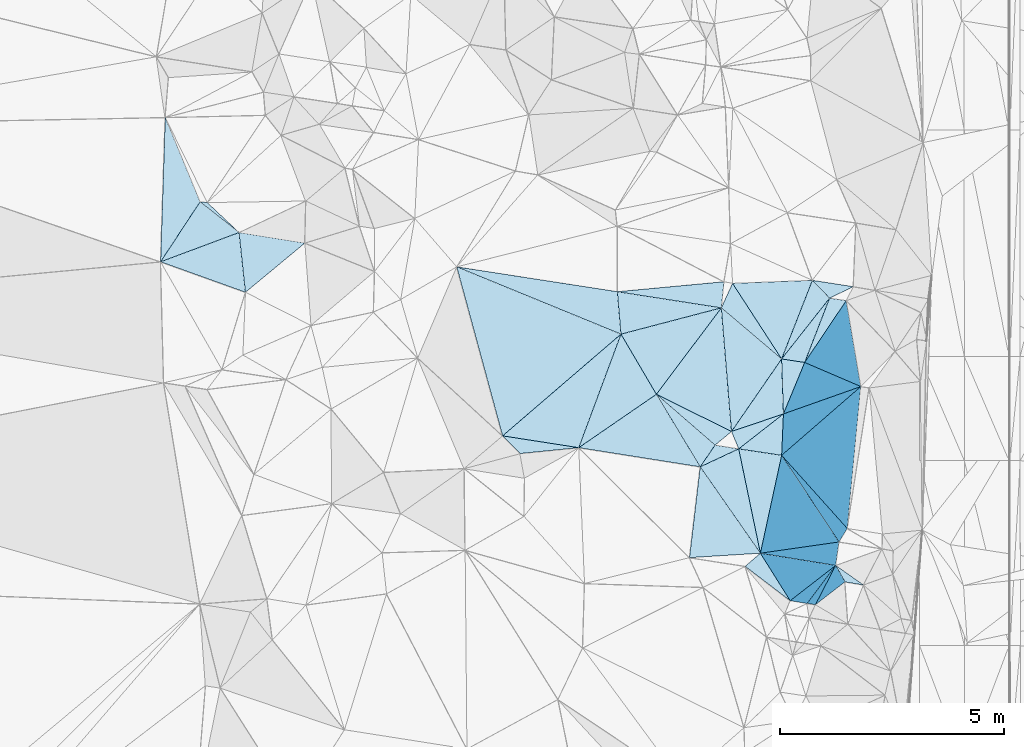
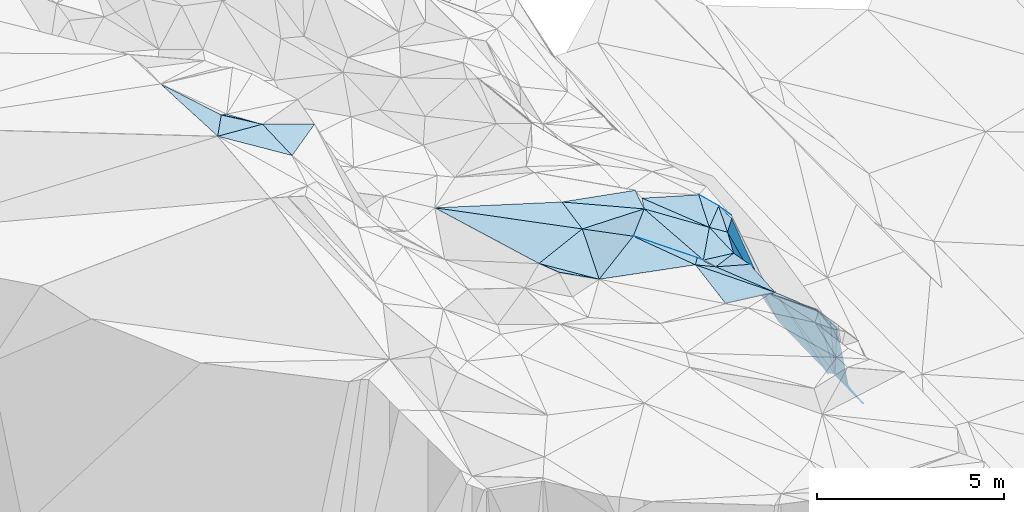
# One storey, part 133 of 275: 45 plates.
"""IFC2X3 building model written with IfcOpenShell, lengths in millimetres."""

from ifc_helpers import new_model, si_unit, frame, origin_with_axes, place, context, subcontext, project, spatial, polyline, outline, extrude, material, type_object, element, save


model = new_model("IFC2X3")

# Units and contexts
model_context = context("Model", 3, precision=1e-05, world=origin_with_axes())
body_context = subcontext(model_context, "Body", "Model", "MODEL_VIEW")
ifc_project = project(units=[si_unit("LENGTHUNIT", "METRE", prefix="MILLI"), si_unit("AREAUNIT", "SQUARE_METRE"), si_unit("VOLUMEUNIT", "CUBIC_METRE"), si_unit("MASSUNIT", "GRAM", prefix="KILO"), si_unit("TIMEUNIT", "SECOND"), si_unit("PLANEANGLEUNIT", "RADIAN"), si_unit("SOLIDANGLEUNIT", "STERADIAN"), si_unit("THERMODYNAMICTEMPERATUREUNIT", "DEGREE_CELSIUS"), si_unit("LUMINOUSINTENSITYUNIT", "LUMEN")], contexts=[model_context])

# Site, building, storey
site_placement = place(None, origin_with_axes())
site = spatial("IfcSite", under=ifc_project, at=site_placement, CompositionType="ELEMENT")
building_placement = place(site_placement, origin_with_axes())
building = spatial("IfcBuilding", under=site, at=building_placement, Name="Undefined", CompositionType="ELEMENT")
storey_placement = place(building_placement, origin_with_axes())
storey = spatial("IfcBuildingStorey", under=building, at=storey_placement, Name="Undefined", CompositionType="ELEMENT", Elevation=0.0)

# Plates
ifc_material = material()
plate_type_1 = type_object("IfcPlateType", PredefinedType="NOTDEFINED")
plate_1_placement = place(storey_placement, frame((-103541.846860155, 120689.424608109, 51749.5258270343), z_axis=(-0.131431408662991, -0.288877952959774, -0.94830127760677), x_axis=(-0.498027157228979, 0.846359246824753, -0.188798771120629)))
element("IfcPlate", 1, at=plate_1_placement, inside=storey, type_object=plate_type_1, material=ifc_material, Name="00", context=body_context, shape_type="SweptSolid", body=[
    extrude(outline(polyline([(0.0, 0.0), (1588.99340820313, -1.13286660052836e-08), (1061.17492675781, 2311.38647460938), (0.0, 0.0)])), frame((-8.85201319254618e-08, 2.18876761149539e-07, -0.5000001331573), z_axis=(0.0, 0.0, 1.0), x_axis=(1.0, 0.0, 0.0)), (0.0, 0.0, 1.0), 1.0),
])
plate_type_2 = type_object("IfcPlateType", PredefinedType="NOTDEFINED")
plate_2_placement = place(storey_placement, frame((-100226.529970155, 121400.937485137, 50289.5630769742), z_axis=(-0.483352519640006, 0.0532796834257402, -0.87380296239582), x_axis=(-0.86409887648363, 0.131009605801975, 0.485972854023082)))
element("IfcPlate", 2, at=plate_2_placement, inside=storey, type_object=plate_type_2, material=ifc_material, Name="00", context=body_context, shape_type="SweptSolid", body=[
    extrude(outline(polyline([(0.0, 0.0), (596.741149902344, 2.91038304567337e-11), (-399.168060302734, 1505.07971191406), (0.0, 0.0)])), frame((-8.85201319254618e-08, 2.18876761149539e-07, -0.5000001331573), z_axis=(0.0, 0.0, 1.0), x_axis=(1.0, 0.0, 0.0)), (0.0, 0.0, 1.0), 1.0),
])
plate_type_3 = type_object("IfcPlateType", PredefinedType="NOTDEFINED")
plate_3_placement = place(storey_placement, frame((-99670.4874775503, 122838.670815847, 50069.7001514242), z_axis=(-0.77295251631372, 0.207269783527302, -0.599652936589853), x_axis=(0.59631552323439, -0.0854564328444867, -0.798188570975049)))
element("IfcPlate", 3, at=plate_3_placement, inside=storey, type_object=plate_type_3, material=ifc_material, Name="00", context=body_context, shape_type="SweptSolid", body=[
    extrude(outline(polyline([(0.0, 0.0), (626.418395996094, -1.62981450557709e-09), (-384.407623291016, 1508.91711425781), (0.0, 0.0)])), frame((-8.85201319254618e-08, 2.18876761149539e-07, -0.5000001331573), z_axis=(0.0, 0.0, 1.0), x_axis=(1.0, 0.0, 0.0)), (0.0, 0.0, 1.0), 1.0),
])
plate_type_4 = type_object("IfcPlateType", PredefinedType="NOTDEFINED")
plate_4_placement = place(storey_placement, frame((-113742.713337974, 124992.402034436, 56659.5075099544), z_axis=(-0.108946506484557, 0.134320696726159, -0.984930763635602), x_axis=(0.987147536895486, -0.101922643665445, -0.123091490808351)))
element("IfcPlate", 4, at=plate_4_placement, inside=storey, type_object=plate_type_4, material=ifc_material, Name="00", context=body_context, shape_type="SweptSolid", body=[
    extrude(outline(polyline([(0.0, 0.0), (162.480773925781, -1.12049747258425e-09), (953.959045410156, 597.37939453125), (0.0, 0.0)])), frame((-8.85201319254618e-08, 2.18876761149539e-07, -0.5000001331573), z_axis=(0.0, 0.0, 1.0), x_axis=(1.0, 0.0, 0.0)), (0.0, 0.0, 1.0), 1.0),
])
plate_type_5 = type_object("IfcPlateType", PredefinedType="NOTDEFINED")
plate_5_placement = place(storey_placement, frame((-114521.961867729, 126878.314157628, 56799.5320666734), z_axis=(-0.34484448311101, -0.072992193626114, -0.935817515404338), x_axis=(0.380916672105907, -0.922072470354693, -0.0684459518580531)))
element("IfcPlate", 5, at=plate_5_placement, inside=storey, type_object=plate_type_5, material=ifc_material, Name="00", context=body_context, shape_type="SweptSolid", body=[
    extrude(outline(polyline([(0.0, 0.0), (2045.40954589844, 7.27595761418343e-09), (2916.67749023438, 1416.04797363281), (0.0, 0.0)])), frame((-8.85201319254618e-08, 2.18876761149539e-07, -0.5000001331573), z_axis=(0.0, 0.0, 1.0), x_axis=(1.0, 0.0, 0.0)), (0.0, 0.0, 1.0), 1.0),
])
plate_type_6 = type_object("IfcPlateType", PredefinedType="NOTDEFINED")
plate_6_placement = place(storey_placement, frame((-106979.791347258, 119760.129287109, 52629.5671899725), z_axis=(-0.494926142917459, -0.0763462852968208, -0.865574582446956), x_axis=(0.865298196313905, -0.13434608578949, -0.482918378909879)))
element("IfcPlate", 6, at=plate_6_placement, inside=storey, type_object=plate_type_6, material=ifc_material, Name="00", context=body_context, shape_type="SweptSolid", body=[
    extrude(outline(polyline([(0.0, 0.0), (1967.20617675781, 1.2732925824821e-08), (485.002563476563, 333.575378417969), (0.0, 0.0)])), frame((-8.85201319254618e-08, 2.18876761149539e-07, -0.5000001331573), z_axis=(0.0, 0.0, 1.0), x_axis=(1.0, 0.0, 0.0)), (0.0, 0.0, 1.0), 1.0),
])
plate_type_7 = type_object("IfcPlateType", PredefinedType="NOTDEFINED")
plate_7_placement = place(storey_placement, frame((-100550.887940375, 116074.807698265, 51109.8012730318), z_axis=(-0.801516270821083, -0.446807466458968, -0.397410059668328), x_axis=(-0.527769777279548, 0.841029329900626, 0.118864327858281)))
element("IfcPlate", 7, at=plate_7_placement, inside=storey, type_object=plate_type_7, material=ifc_material, Name="00", context=body_context, shape_type="SweptSolid", body=[
    extrude(outline(polyline([(0.0, 0.0), (1261.94299316406, 1.00990291684866e-08), (-223.147964477539, 3201.93774414063), (0.0, 0.0)])), frame((-8.85201319254618e-08, 2.18876761149539e-07, -0.5000001331573), z_axis=(0.0, 0.0, 1.0), x_axis=(1.0, 0.0, 0.0)), (0.0, 0.0, 1.0), 1.0),
])
plate_type_8 = type_object("IfcPlateType", PredefinedType="NOTDEFINED")
plate_8_placement = place(storey_placement, frame((-102089.213282242, 122622.15882844, 50959.5547884261), z_axis=(-0.255608616383563, 0.376682940142847, -0.890378682267169), x_axis=(-0.933088162262274, 0.144894729744456, 0.329168647866552)))
element("IfcPlate", 8, at=plate_8_placement, inside=storey, type_object=plate_type_8, material=ifc_material, Name="00", context=body_context, shape_type="SweptSolid", body=[
    extrude(outline(polyline([(0.0, 0.0), (2491.12426757813, -9.89530235528946e-10), (105.213539123535, 621.313232421875), (0.0, 0.0)])), frame((-8.85201319254618e-08, 2.18876761149539e-07, -0.5000001331573), z_axis=(0.0, 0.0, 1.0), x_axis=(1.0, 0.0, 0.0)), (0.0, 0.0, 1.0), 1.0),
])
plate_type_9 = type_object("IfcPlateType", PredefinedType="NOTDEFINED")
plate_9_placement = place(storey_placement, frame((-100741.518688429, 119325.498111295, 50679.7574045136), z_axis=(-0.871375474883177, -0.0730486686952182, -0.485148094682411), x_axis=(0.0414887717409885, 0.97434003179237, -0.221224284983065)))
element("IfcPlate", 9, at=plate_9_placement, inside=storey, type_object=plate_type_9, material=ifc_material, Name="00", context=body_context, shape_type="SweptSolid", body=[
    extrude(outline(polyline([(0.0, 0.0), (949.262878417969, 8.00355337560177e-10), (2325.17260742188, 3422.77270507813), (0.0, 0.0)])), frame((-8.85201319254618e-08, 2.18876761149539e-07, -0.5000001331573), z_axis=(0.0, 0.0, 1.0), x_axis=(1.0, 0.0, 0.0)), (0.0, 0.0, 1.0), 1.0),
])
plate_type_10 = type_object("IfcPlateType", PredefinedType="NOTDEFINED")
plate_10_placement = place(storey_placement, frame((-112728.423283851, 122969.869598107, 56209.5417378106), z_axis=(-0.375448268043942, 0.138240768234035, -0.916475906950569), x_axis=(-0.862607535053377, 0.309589091692787, 0.400078535757634)))
element("IfcPlate", 10, at=plate_10_placement, inside=storey, type_object=plate_type_10, material=ifc_material, Name="00", context=body_context, shape_type="SweptSolid", body=[
    extrude(outline(polyline([(0.0, 0.0), (2199.56811523438, 2.35741026699543e-09), (640.762145996094, 1209.76196289063), (0.0, 0.0)])), frame((-8.85201319254618e-08, 2.18876761149539e-07, -0.5000001331573), z_axis=(0.0, 0.0, 1.0), x_axis=(1.0, 0.0, 0.0)), (0.0, 0.0, 1.0), 1.0),
])
plate_type_11 = type_object("IfcPlateType", PredefinedType="NOTDEFINED")
plate_11_placement = place(storey_placement, frame((-113742.80589089, 124992.279483565, 56659.5252998992), z_axis=(-0.29404704903762, -0.110761845372307, -0.949351434697388), x_axis=(0.774589887403005, -0.609520922904891, -0.168803882876462)))
element("IfcPlate", 11, at=plate_11_placement, inside=storey, type_object=plate_type_11, material=ifc_material, Name="00", context=body_context, shape_type="SweptSolid", body=[
    extrude(outline(polyline([(0.0, 0.0), (1125.56652832031, 1.1423253454268e-09), (61.2136192321777, 1661.4912109375), (0.0, 0.0)])), frame((-8.85201319254618e-08, 2.18876761149539e-07, -0.5000001331573), z_axis=(0.0, 0.0, 1.0), x_axis=(1.0, 0.0, 0.0)), (0.0, 0.0, 1.0), 1.0),
])
plate_type_12 = type_object("IfcPlateType", PredefinedType="NOTDEFINED")
plate_12_placement = place(storey_placement, frame((-101862.228640944, 119857.739316437, 50889.5565335684), z_axis=(-0.46172321911077, -0.0154724940966156, -0.886889097272268), x_axis=(-0.814508038136902, 0.403341117743197, 0.417004314783484)))
element("IfcPlate", 12, at=plate_12_placement, inside=storey, type_object=plate_type_12, material=ifc_material, Name="00", context=body_context, shape_type="SweptSolid", body=[
    extrude(outline(polyline([(0.0, 0.0), (2062.32885742188, -8.46921466290951e-09), (1329.080078125, 2435.353515625), (0.0, 0.0)])), frame((-8.85201319254618e-08, 2.18876761149539e-07, -0.5000001331573), z_axis=(0.0, 0.0, 1.0), x_axis=(1.0, 0.0, 0.0)), (0.0, 0.0, 1.0), 1.0),
])
plate_type_13 = type_object("IfcPlateType", PredefinedType="NOTDEFINED")
plate_13_placement = place(storey_placement, frame((-99986.4311561274, 115985.240943907, 50419.8036994692), z_axis=(-0.603850024931311, -0.693731928358291, -0.392557204706197), x_axis=(-0.611790406562096, 0.0876740989038801, 0.786146138335601)))
element("IfcPlate", 13, at=plate_13_placement, inside=storey, type_object=plate_type_13, material=ifc_material, Name="00", context=body_context, shape_type="SweptSolid", body=[
    extrude(outline(polyline([(0.0, 0.0), (305.286743164063, -2.7648638933897e-10), (-1969.29602050781, 1470.26293945313), (0.0, 0.0)])), frame((-8.85201319254618e-08, 2.18876761149539e-07, -0.5000001331573), z_axis=(0.0, 0.0, 1.0), x_axis=(1.0, 0.0, 0.0)), (0.0, 0.0, 1.0), 1.0),
])
plate_type_14 = type_object("IfcPlateType", PredefinedType="NOTDEFINED")
plate_14_placement = place(storey_placement, frame((-102230.427140432, 119552.697233883, 51269.6111809844), z_axis=(-0.549469294641196, -0.305664369536935, -0.77759423058694), x_axis=(-0.728356746078006, 0.631228113644776, 0.2665474047653)))
element("IfcPlate", 14, at=plate_14_placement, inside=storey, type_object=plate_type_14, material=ifc_material, Name="00", context=body_context, shape_type="SweptSolid", body=[
    extrude(outline(polyline([(0.0, 0.0), (1800.80541992188, 1.5788828022778e-09), (-176.976364135742, 584.447937011719), (0.0, 0.0)])), frame((-8.85201319254618e-08, 2.18876761149539e-07, -0.5000001331573), z_axis=(0.0, 0.0, 1.0), x_axis=(1.0, 0.0, 0.0)), (0.0, 0.0, 1.0), 1.0),
])
plate_type_15 = type_object("IfcPlateType", PredefinedType="NOTDEFINED")
plate_15_placement = place(storey_placement, frame((-101701.48378919, 119469.549244421, 50849.5281222413), z_axis=(-0.328493757168184, -0.0387278729901455, -0.943711822197428), x_axis=(-0.380737016365414, 0.919812811058864, 0.0947824719088557)))
element("IfcPlate", 15, at=plate_15_placement, inside=storey, type_object=plate_type_15, material=ifc_material, Name="00", context=body_context, shape_type="SweptSolid", body=[
    extrude(outline(polyline([(0.0, 0.0), (422.018951416016, 8.14907252788544e-10), (301.645202636719, 1289.34484863281), (0.0, 0.0)])), frame((-8.85201319254618e-08, 2.18876761149539e-07, -0.5000001331573), z_axis=(0.0, 0.0, 1.0), x_axis=(1.0, 0.0, 0.0)), (0.0, 0.0, 1.0), 1.0),
])
plate_type_16 = type_object("IfcPlateType", PredefinedType="NOTDEFINED")
plate_16_placement = place(storey_placement, frame((-100742.067157443, 121479.089966986, 50579.5186901572), z_axis=(-0.271011619986809, 0.000598922214104097, -0.962575889540304), x_axis=(-0.745502314234174, 0.632459540765163, 0.210288441828388)))
element("IfcPlate", 16, at=plate_16_placement, inside=storey, type_object=plate_type_16, material=ifc_material, Name="00", context=body_context, shape_type="SweptSolid", body=[
    extrude(outline(polyline([(0.0, 0.0), (1807.04174804688, 8.87666828930378e-09), (1952.52819824219, 588.416259765625), (0.0, 0.0)])), frame((-8.85201319254618e-08, 2.18876761149539e-07, -0.5000001331573), z_axis=(0.0, 0.0, 1.0), x_axis=(1.0, 0.0, 0.0)), (0.0, 0.0, 1.0), 1.0),
])
plate_type_17 = type_object("IfcPlateType", PredefinedType="NOTDEFINED")
plate_17_placement = place(storey_placement, frame((-103541.982905747, 120689.528675815, 51749.5442755358), z_axis=(-0.40351258670929, -0.0807452370194401, -0.911404300552643), x_axis=(0.728356746074451, -0.631228113648151, -0.266547404767021)))
element("IfcPlate", 17, at=plate_17_placement, inside=storey, type_object=plate_type_17, material=ifc_material, Name="00", context=body_context, shape_type="SweptSolid", body=[
    extrude(outline(polyline([(0.0, 0.0), (1800.80541992188, 1.5788828022778e-09), (1814.96569824219, 618.061096191406), (0.0, 0.0)])), frame((-8.85201319254618e-08, 2.18876761149539e-07, -0.5000001331573), z_axis=(0.0, 0.0, 1.0), x_axis=(1.0, 0.0, 0.0)), (0.0, 0.0, 1.0), 1.0),
])
plate_type_18 = type_object("IfcPlateType", PredefinedType="NOTDEFINED")
plate_18_placement = place(storey_placement, frame((-102089.220352531, 122621.971593678, 50959.5185117012), z_axis=(-0.269732162540713, 0.00222573903659112, -0.962932815193693), x_axis=(0.745502314238582, -0.632459540761654, -0.210288441823312)))
element("IfcPlate", 18, at=plate_18_placement, inside=storey, type_object=plate_type_18, material=ifc_material, Name="00", context=body_context, shape_type="SweptSolid", body=[
    extrude(outline(polyline([(0.0, 0.0), (1807.04174804688, 8.87666828930378e-09), (1932.27404785156, 1990.90856933594), (0.0, 0.0)])), frame((-8.85201319254618e-08, 2.18876761149539e-07, -0.5000001331573), z_axis=(0.0, 0.0, 1.0), x_axis=(1.0, 0.0, 0.0)), (0.0, 0.0, 1.0), 1.0),
])
plate_type_19 = type_object("IfcPlateType", PredefinedType="NOTDEFINED")
plate_19_placement = place(storey_placement, frame((-99532.995236247, 116863.941100128, 48169.7336891766), z_axis=(-0.840983119391418, -0.0954332160620175, -0.53257853333639), x_axis=(0.526493796418976, -0.371211237004124, -0.764857176114732)))
element("IfcPlate", 19, at=plate_19_placement, inside=storey, type_object=plate_type_19, material=ifc_material, Name="00", context=body_context, shape_type="SweptSolid", body=[
    extrude(outline(polyline([(0.0, 0.0), (1176.69030761719, 1.57160684466362e-09), (444.127075195313, 219.888946533203), (0.0, 0.0)])), frame((-8.85201319254618e-08, 2.18876761149539e-07, -0.5000001331573), z_axis=(0.0, 0.0, 1.0), x_axis=(1.0, 0.0, 0.0)), (0.0, 0.0, 1.0), 1.0),
])
plate_type_20 = type_object("IfcPlateType", PredefinedType="NOTDEFINED")
plate_20_placement = place(storey_placement, frame((-100742.112039479, 121479.125392568, 50579.5350233442), z_axis=(-0.360783035322879, 0.0714400955290196, -0.929909626885331), x_axis=(0.0325974243393763, -0.995486879358179, -0.0891250859867933)))
element("IfcPlate", 20, at=plate_20_placement, inside=storey, type_object=plate_type_20, material=ifc_material, Name="00", context=body_context, shape_type="SweptSolid", body=[
    extrude(outline(polyline([(0.0, 0.0), (1234.22045898438, -5.58793544769287e-09), (1549.88525390625, 1255.88842773438), (0.0, 0.0)])), frame((-8.85201319254618e-08, 2.18876761149539e-07, -0.5000001331573), z_axis=(0.0, 0.0, 1.0), x_axis=(1.0, 0.0, 0.0)), (0.0, 0.0, 1.0), 1.0),
])
plate_type_21 = type_object("IfcPlateType", PredefinedType="NOTDEFINED")
plate_21_placement = place(storey_placement, frame((-101216.742749656, 117136.238297007, 51259.5793100965), z_axis=(-0.480428425201294, -0.247671150915636, -0.841336751403818), x_axis=(-0.569712309594849, 0.817470260301661, 0.0846773748910366)))
element("IfcPlate", 21, at=plate_21_placement, inside=storey, type_object=plate_type_21, material=ifc_material, Name="00", context=body_context, shape_type="SweptSolid", body=[
    extrude(outline(polyline([(0.0, 0.0), (2361.90600585938, 8.70204530656338e-09), (2148.8154296875, 1108.86987304688), (0.0, 0.0)])), frame((-8.85201319254618e-08, 2.18876761149539e-07, -0.5000001331573), z_axis=(0.0, 0.0, 1.0), x_axis=(1.0, 0.0, 0.0)), (0.0, 0.0, 1.0), 1.0),
])
plate_type_22 = type_object("IfcPlateType", PredefinedType="NOTDEFINED")
plate_22_placement = place(storey_placement, frame((-100701.799625486, 120250.33507261, 50469.5214105285), z_axis=(-0.200766038471775, -0.208769099764669, -0.957135549846415), x_axis=(-0.0414887717289393, -0.974340031793671, 0.221224284979592)))
element("IfcPlate", 22, at=plate_22_placement, inside=storey, type_object=plate_type_22, material=ifc_material, Name="00", context=body_context, shape_type="SweptSolid", body=[
    extrude(outline(polyline([(0.0, 0.0), (949.262878417969, 8.00355337560177e-10), (886.371948242188, 983.740173339844), (0.0, 0.0)])), frame((-8.85201319254618e-08, 2.18876761149539e-07, -0.5000001331573), z_axis=(0.0, 0.0, 1.0), x_axis=(1.0, 0.0, 0.0)), (0.0, 0.0, 1.0), 1.0),
])
plate_type_23 = type_object("IfcPlateType", PredefinedType="NOTDEFINED")
plate_23_placement = place(storey_placement, frame((-104333.281442112, 122034.575677004, 51449.5426835672), z_axis=(-0.276873322370097, 0.29473957989941, -0.91458719835807), x_axis=(-0.0797848573698835, 0.941458303007926, 0.327552499962836)))
element("IfcPlate", 23, at=plate_23_placement, inside=storey, type_object=plate_type_23, material=ifc_material, Name="00", context=body_context, shape_type="SweptSolid", body=[
    extrude(outline(polyline([(0.0, 0.0), (1007.47210693359, -5.83531800657511e-09), (213.603927612305, 2361.244140625), (0.0, 0.0)])), frame((-8.85201319254618e-08, 2.18876761149539e-07, -0.5000001331573), z_axis=(0.0, 0.0, 1.0), x_axis=(1.0, 0.0, 0.0)), (0.0, 0.0, 1.0), 1.0),
])
plate_type_24 = type_object("IfcPlateType", PredefinedType="NOTDEFINED")
plate_24_placement = place(storey_placement, frame((-100550.726125121, 116074.941939383, 51109.569913489), z_axis=(-0.477889012652295, -0.178325172223778, -0.860129190608931), x_axis=(-0.757948783837935, 0.57863717151048, 0.301152228656781)))
element("IfcPlate", 24, at=plate_24_placement, inside=storey, type_object=plate_type_24, material=ifc_material, Name="00", context=body_context, shape_type="SweptSolid", body=[
    extrude(outline(polyline([(0.0, 0.0), (1328.23193359375, 5.56610757485032e-09), (1164.10388183594, 487.198120117188), (0.0, 0.0)])), frame((-8.85201319254618e-08, 2.18876761149539e-07, -0.5000001331573), z_axis=(0.0, 0.0, 1.0), x_axis=(1.0, 0.0, 0.0)), (0.0, 0.0, 1.0), 1.0),
])
plate_type_25 = type_object("IfcPlateType", PredefinedType="NOTDEFINED")
plate_25_placement = place(storey_placement, frame((-100741.517646329, 119325.593728318, 50679.7599971177), z_axis=(-0.869290872854774, 0.118190313701849, -0.479962944526392), x_axis=(0.389385195380708, -0.43439224899537, -0.8122084360748)))
element("IfcPlate", 25, at=plate_25_placement, inside=storey, type_object=plate_type_25, material=ifc_material, Name="00", context=body_context, shape_type="SweptSolid", body=[
    extrude(outline(polyline([(0.0, 0.0), (3767.505859375, 1.32713466882706e-08), (3614.93798828125, 410.393798828125), (0.0, 0.0)])), frame((-8.85201319254618e-08, 2.18876761149539e-07, -0.5000001331573), z_axis=(0.0, 0.0, 1.0), x_axis=(1.0, 0.0, 0.0)), (0.0, 0.0, 1.0), 1.0),
])
plate_type_26 = type_object("IfcPlateType", PredefinedType="NOTDEFINED")
plate_26_placement = place(storey_placement, frame((-100701.94026098, 120250.470679995, 50469.5630154226), z_axis=(-0.482030028689172, 0.0624576428661563, -0.873925680072121), x_axis=(-0.0325974243505657, 0.995486879357683, 0.0891250859882445)))
element("IfcPlate", 26, at=plate_26_placement, inside=storey, type_object=plate_type_26, material=ifc_material, Name="00", context=body_context, shape_type="SweptSolid", body=[
    extrude(outline(polyline([(0.0, 0.0), (1234.22045898438, -5.58793544769287e-09), (1113.73950195313, 584.452209472656), (0.0, 0.0)])), frame((-8.85201319254618e-08, 2.18876761149539e-07, -0.5000001331573), z_axis=(0.0, 0.0, 1.0), x_axis=(1.0, 0.0, 0.0)), (0.0, 0.0, 1.0), 1.0),
])
plate_type_27 = type_object("IfcPlateType", PredefinedType="NOTDEFINED")
plate_27_placement = place(storey_placement, frame((-104333.075349968, 122034.358695552, 51449.509489574), z_axis=(0.135310557615119, -0.139206381422751, -0.980975349521622), x_axis=(0.49802715722236, -0.846359246829393, 0.188798771117288)))
element("IfcPlate", 27, at=plate_27_placement, inside=storey, type_object=plate_type_27, material=ifc_material, Name="00", context=body_context, shape_type="SweptSolid", body=[
    extrude(outline(polyline([(0.0, 0.0), (1588.99340820313, -1.13286660052836e-08), (1721.71887207031, 2103.39819335938), (0.0, 0.0)])), frame((-8.85201319254618e-08, 2.18876761149539e-07, -0.5000001331573), z_axis=(0.0, 0.0, 1.0), x_axis=(1.0, 0.0, 0.0)), (0.0, 0.0, 1.0), 1.0),
])
plate_type_28 = type_object("IfcPlateType", PredefinedType="NOTDEFINED")
plate_28_placement = place(storey_placement, frame((-99533.0281184381, 116863.840097702, 48169.8505274639), z_axis=(-0.906746001628498, -0.29743820597445, -0.298901659676612), x_axis=(0.416498651386256, -0.742485403038423, -0.524637302970634)))
element("IfcPlate", 28, at=plate_28_placement, inside=storey, type_object=plate_type_28, material=ifc_material, Name="00", context=body_context, shape_type="SweptSolid", body=[
    extrude(outline(polyline([(0.0, 0.0), (495.580474853516, -2.11002770811319e-10), (-717.138854980469, 2350.640625), (0.0, 0.0)])), frame((-8.85201319254618e-08, 2.18876761149539e-07, -0.5000001331573), z_axis=(0.0, 0.0, 1.0), x_axis=(1.0, 0.0, 0.0)), (0.0, 0.0, 1.0), 1.0),
])
plate_type_29 = type_object("IfcPlateType", PredefinedType="NOTDEFINED")
plate_29_placement = place(storey_placement, frame((-99670.4508953865, 122838.45027632, 50069.6624709867), z_axis=(-0.699778923062208, -0.233806966262561, -0.675013897164343), x_axis=(-0.627878852442615, 0.651972237964554, 0.425088634967857)))
element("IfcPlate", 29, at=plate_29_placement, inside=storey, type_object=plate_type_29, material=ifc_material, Name="00", context=body_context, shape_type="SweptSolid", body=[
    extrude(outline(polyline([(0.0, 0.0), (611.637145996094, -7.34871719032526e-10), (-438.331787109375, 752.306640625), (0.0, 0.0)])), frame((-8.85201319254618e-08, 2.18876761149539e-07, -0.5000001331573), z_axis=(0.0, 0.0, 1.0), x_axis=(1.0, 0.0, 0.0)), (0.0, 0.0, 1.0), 1.0),
])
plate_type_30 = type_object("IfcPlateType", PredefinedType="NOTDEFINED")
plate_30_placement = place(storey_placement, frame((-102562.413391558, 119067.203897725, 51459.6066201978), z_axis=(-0.607851130657934, 0.107689277198541, -0.786714702121632), x_axis=(0.536953372818032, 0.785638536151862, -0.307332337921831)))
element("IfcPlate", 30, at=plate_30_placement, inside=storey, type_object=plate_type_30, material=ifc_material, Name="00", context=body_context, shape_type="SweptSolid", body=[
    extrude(outline(polyline([(0.0, 0.0), (618.223266601563, 3.49245965480804e-10), (965.832336425781, 584.951232910156), (0.0, 0.0)])), frame((-8.85201319254618e-08, 2.18876761149539e-07, -0.5000001331573), z_axis=(0.0, 0.0, 1.0), x_axis=(1.0, 0.0, 0.0)), (0.0, 0.0, 1.0), 1.0),
])
plate_type_31 = type_object("IfcPlateType", PredefinedType="NOTDEFINED")
plate_31_placement = place(storey_placement, frame((-108004.806452899, 123538.417136166, 52509.5306992463), z_axis=(-0.142150807506572, 0.314495687797678, -0.938555065130382), x_axis=(0.96889703997134, -0.149828539686607, -0.196951604792028)))
element("IfcPlate", 31, at=plate_31_placement, inside=storey, type_object=plate_type_31, material=ifc_material, Name="00", context=body_context, shape_type="SweptSolid", body=[
    extrude(outline(polyline([(0.0, 0.0), (3706.49438476563, 1.20489858090878e-08), (3991.48046875, 966.324401855469), (0.0, 0.0)])), frame((-8.85201319254618e-08, 2.18876761149539e-07, -0.5000001331573), z_axis=(0.0, 0.0, 1.0), x_axis=(1.0, 0.0, 0.0)), (0.0, 0.0, 1.0), 1.0),
])
plate_type_32 = type_object("IfcPlateType", PredefinedType="NOTDEFINED")
plate_32_placement = place(storey_placement, frame((-100173.193759468, 116011.999268678, 50659.8034526401), z_axis=(-0.586048174918545, -0.708560776686435, -0.393051093900219), x_axis=(-0.639151309523926, 0.106096074900835, 0.761727790240377)))
element("IfcPlate", 32, at=plate_32_placement, inside=storey, type_object=plate_type_32, material=ifc_material, Name="00", context=body_context, shape_type="SweptSolid", body=[
    extrude(outline(polyline([(0.0, 0.0), (590.76220703125, -1.60071067512035e-10), (-2215.6123046875, 1557.71069335938), (0.0, 0.0)])), frame((-8.85201319254618e-08, 2.18876761149539e-07, -0.5000001331573), z_axis=(0.0, 0.0, 1.0), x_axis=(1.0, 0.0, 0.0)), (0.0, 0.0, 1.0), 1.0),
])
plate_type_33 = type_object("IfcPlateType", PredefinedType="NOTDEFINED")
plate_33_placement = place(storey_placement, frame((-101701.419984383, 119469.463666085, 50849.5215450964), z_axis=(-0.200885895903764, -0.209886256334783, -0.956866038810403), x_axis=(0.974119253370331, -0.14611635975723, -0.172457790849019)))
element("IfcPlate", 33, at=plate_33_placement, inside=storey, type_object=plate_type_33, material=ifc_material, Name="00", context=body_context, shape_type="SweptSolid", body=[
    extrude(outline(polyline([(0.0, 0.0), (985.748474121094, 6.69388100504875e-09), (742.481506347656, 2301.24340820313), (0.0, 0.0)])), frame((-8.85201319254618e-08, 2.18876761149539e-07, -0.5000001331573), z_axis=(0.0, 0.0, 1.0), x_axis=(1.0, 0.0, 0.0)), (0.0, 0.0, 1.0), 1.0),
])
plate_type_34 = type_object("IfcPlateType", PredefinedType="NOTDEFINED")
plate_34_placement = place(storey_placement, frame((-102801.733883711, 117036.92111809, 51509.5060623388), z_axis=(-0.155418362906808, -0.0059902547658688, -0.98783057723438), x_axis=(0.117142310785897, 0.992814099432875, -0.0244508280234004)))
element("IfcPlate", 34, at=plate_34_placement, inside=storey, type_object=plate_type_34, material=ifc_material, Name="00", context=body_context, shape_type="SweptSolid", body=[
    extrude(outline(polyline([(0.0, 0.0), (2044.92053222656, 7.71251507103443e-10), (290.524749755859, 1581.35876464844), (0.0, 0.0)])), frame((-8.85201319254618e-08, 2.18876761149539e-07, -0.5000001331573), z_axis=(0.0, 0.0, 1.0), x_axis=(1.0, 0.0, 0.0)), (0.0, 0.0, 1.0), 1.0),
])
plate_type_35 = type_object("IfcPlateType", PredefinedType="NOTDEFINED")
plate_35_placement = place(storey_placement, frame((-101216.940087539, 117136.295425124, 51259.7674047834), z_axis=(-0.875122130514369, -0.133415524788157, -0.46514680954457), x_axis=(0.460438995299129, 0.0661081031085479, -0.885226327167984)))
element("IfcPlate", 35, at=plate_35_placement, inside=storey, type_object=plate_type_35, material=ifc_material, Name="00", context=body_context, shape_type="SweptSolid", body=[
    extrude(outline(polyline([(0.0, 0.0), (3818.23266601563, -2.96859070658684e-09), (3492.68920898438, 508.941619873047), (0.0, 0.0)])), frame((-8.85201319254618e-08, 2.18876761149539e-07, -0.5000001331573), z_axis=(0.0, 0.0, 1.0), x_axis=(1.0, 0.0, 0.0)), (0.0, 0.0, 1.0), 1.0),
])
plate_type_36 = type_object("IfcPlateType", PredefinedType="NOTDEFINED")
plate_36_placement = place(storey_placement, frame((-100741.526516083, 119325.57054997, 50679.7719631791), z_axis=(-0.887061619938994, 0.0718212048061963, -0.456030039549364), x_axis=(0.352552945332177, -0.532345193990521, -0.769620045979054)))
element("IfcPlate", 36, at=plate_36_placement, inside=storey, type_object=plate_type_36, material=ifc_material, Name="00", context=body_context, shape_type="SweptSolid", body=[
    extrude(outline(polyline([(0.0, 0.0), (3638.15893554688, -1.07975210994482e-08), (551.4052734375, 2247.41015625), (0.0, 0.0)])), frame((-8.85201319254618e-08, 2.18876761149539e-07, -0.5000001331573), z_axis=(0.0, 0.0, 1.0), x_axis=(1.0, 0.0, 0.0)), (0.0, 0.0, 1.0), 1.0),
])
plate_type_37 = type_object("IfcPlateType", PredefinedType="NOTDEFINED")
plate_37_placement = place(storey_placement, frame((-102562.138300836, 119067.220958149, 51459.5058721635), z_axis=(-0.0576779884307989, 0.141810470284725, -0.988212042108475), x_axis=(-0.984613885491516, 0.155470021776515, 0.0797782478255145)))
element("IfcPlate", 37, at=plate_37_placement, inside=storey, type_object=plate_type_37, material=ifc_material, Name="00", context=body_context, shape_type="SweptSolid", body=[
    extrude(outline(polyline([(0.0, 0.0), (2757.64404296875, 5.98083715885878e-09), (1239.97155761719, 1462.38525390625), (0.0, 0.0)])), frame((-8.85201319254618e-08, 2.18876761149539e-07, -0.5000001331573), z_axis=(0.0, 0.0, 1.0), x_axis=(1.0, 0.0, 0.0)), (0.0, 0.0, 1.0), 1.0),
])
plate_type_38 = type_object("IfcPlateType", PredefinedType="NOTDEFINED")
plate_38_placement = place(storey_placement, frame((-105277.560732412, 119495.9294211, 51679.5622607248), z_axis=(-0.473543820543561, 0.0968118124895948, -0.875433448634154), x_axis=(-0.865298196314853, 0.13434608578318, 0.482918378909935)))
element("IfcPlate", 38, at=plate_38_placement, inside=storey, type_object=plate_type_38, material=ifc_material, Name="00", context=body_context, shape_type="SweptSolid", body=[
    extrude(outline(polyline([(0.0, 0.0), (1967.20617675781, 1.2732925824821e-08), (-587.025390625, 2654.0537109375), (0.0, 0.0)])), frame((-8.85201319254618e-08, 2.18876761149539e-07, -0.5000001331573), z_axis=(0.0, 0.0, 1.0), x_axis=(1.0, 0.0, 0.0)), (0.0, 0.0, 1.0), 1.0),
])
plate_type_39 = type_object("IfcPlateType", PredefinedType="NOTDEFINED")
plate_39_placement = place(storey_placement, frame((-99274.518783097, 117688.977253206, 47619.7761990268), z_axis=(-0.893534239335164, 0.0358726233596224, -0.44755973682742), x_axis=(-0.389385195375553, 0.434392249006031, 0.812208436071569)))
element("IfcPlate", 39, at=plate_39_placement, inside=storey, type_object=plate_type_39, material=ifc_material, Name="00", context=body_context, shape_type="SweptSolid", body=[
    extrude(outline(polyline([(0.0, 0.0), (3767.505859375, 1.32713466882706e-08), (976.348876953125, 3054.70825195313), (0.0, 0.0)])), frame((-8.85201319254618e-08, 2.18876761149539e-07, -0.5000001331573), z_axis=(0.0, 0.0, 1.0), x_axis=(1.0, 0.0, 0.0)), (0.0, 0.0, 1.0), 1.0),
])
plate_type_40 = type_object("IfcPlateType", PredefinedType="NOTDEFINED")
plate_40_placement = place(storey_placement, frame((-98971.7805532326, 120862.518535025, 47269.7939761797), z_axis=(-0.841026946357356, 0.350607675306522, -0.412004773657998), x_axis=(-0.378628182140156, 0.1624928568784, 0.911173293700346)))
element("IfcPlate", 40, at=plate_40_placement, inside=storey, type_object=plate_type_40, material=ifc_material, Name="00", context=body_context, shape_type="SweptSolid", body=[
    extrude(outline(polyline([(0.0, 0.0), (3314.40795898438, -9.24046617001295e-09), (2531.25146484375, 1638.67810058594), (0.0, 0.0)])), frame((-8.85201319254618e-08, 2.18876761149539e-07, -0.5000001331573), z_axis=(0.0, 0.0, 1.0), x_axis=(1.0, 0.0, 0.0)), (0.0, 0.0, 1.0), 1.0),
])
plate_type_41 = type_object("IfcPlateType", PredefinedType="NOTDEFINED")
plate_41_placement = place(storey_placement, frame((-100702.130971474, 120250.585705013, 50469.7944972043), z_axis=(-0.863452125688631, 0.292507422131727, -0.410962084189815), x_axis=(0.377977494880899, 0.914687164448659, -0.143109764015007)))
element("IfcPlate", 41, at=plate_41_placement, inside=storey, type_object=plate_type_41, material=ifc_material, Name="00", context=body_context, shape_type="SweptSolid", body=[
    extrude(outline(polyline([(0.0, 0.0), (1257.77575683594, -8.90577211976051e-09), (1671.68103027344, 3288.4619140625), (0.0, 0.0)])), frame((-8.85201319254618e-08, 2.18876761149539e-07, -0.5000001331573), z_axis=(0.0, 0.0, 1.0), x_axis=(1.0, 0.0, 0.0)), (0.0, 0.0, 1.0), 1.0),
])
plate_type_42 = type_object("IfcPlateType", PredefinedType="NOTDEFINED")
plate_42_placement = place(storey_placement, frame((-108004.895000304, 123538.201637241, 52509.5297333104), z_axis=(-0.319237154311115, -0.116497326955165, -0.940487114276237), x_axis=(0.894030373454161, -0.366182020837828, -0.258109315904208)))
element("IfcPlate", 42, at=plate_42_placement, inside=storey, type_object=plate_type_42, material=ifc_material, Name="00", context=body_context, shape_type="SweptSolid", body=[
    extrude(outline(polyline([(0.0, 0.0), (4106.787109375, 1.91648723557591e-08), (2269.048828125, 3192.30615234375), (0.0, 0.0)])), frame((-8.85201319254618e-08, 2.18876761149539e-07, -0.5000001331573), z_axis=(0.0, 0.0, 1.0), x_axis=(1.0, 0.0, 0.0)), (0.0, 0.0, 1.0), 1.0),
])
plate_type_43 = type_object("IfcPlateType", PredefinedType="NOTDEFINED")
plate_43_placement = place(storey_placement, frame((-100054.387257907, 123237.375133918, 50329.5698906549), z_axis=(-0.504451628692511, 0.0750273024981084, -0.860174085978722), x_axis=(0.62787885243058, -0.651972237972002, -0.425088634974211)))
element("IfcPlate", 43, at=plate_43_placement, inside=storey, type_object=plate_type_43, material=ifc_material, Name="00", context=body_context, shape_type="SweptSolid", body=[
    extrude(outline(polyline([(0.0, 0.0), (611.637145996094, -7.34871719032526e-10), (608.203735351563, 1804.74047851563), (0.0, 0.0)])), frame((-8.85201319254618e-08, 2.18876761149539e-07, -0.5000001331573), z_axis=(0.0, 0.0, 1.0), x_axis=(1.0, 0.0, 0.0)), (0.0, 0.0, 1.0), 1.0),
])
plate_type_44 = type_object("IfcPlateType", PredefinedType="NOTDEFINED")
plate_44_placement = place(storey_placement, frame((-112728.343476568, 122969.882600262, 56209.5187170318), z_axis=(-0.215853727909389, 0.164222564311883, -0.962516554412676), x_axis=(-0.104144037331027, 0.976259889758487, 0.189922739915843)))
element("IfcPlate", 44, at=plate_44_placement, inside=storey, type_object=plate_type_44, material=ifc_material, Name="00", context=body_context, shape_type="SweptSolid", body=[
    extrude(outline(polyline([(0.0, 0.0), (1368.97766113281, 2.3719621822238e-09), (915.719787597656, 1466.30737304688), (0.0, 0.0)])), frame((-8.85201319254618e-08, 2.18876761149539e-07, -0.5000001331573), z_axis=(0.0, 0.0, 1.0), x_axis=(1.0, 0.0, 0.0)), (0.0, 0.0, 1.0), 1.0),
])
plate_type_45 = type_object("IfcPlateType", PredefinedType="NOTDEFINED")
plate_45_placement = place(storey_placement, frame((-101839.399000852, 123169.758547105, 50889.5228842772), z_axis=(-0.298619417541365, -0.0188580130545304, -0.954185945615891), x_axis=(0.953530295857106, 0.0360927532934671, -0.299127544773725)))
element("IfcPlate", 45, at=plate_45_placement, inside=storey, type_object=plate_type_45, material=ifc_material, Name="00", context=body_context, shape_type="SweptSolid", body=[
    extrude(outline(polyline([(0.0, 0.0), (1872.11108398438, 1.00990291684866e-08), (1078.03430175781, 1731.0234375), (0.0, 0.0)])), frame((-8.85201319254618e-08, 2.18876761149539e-07, -0.5000001331573), z_axis=(0.0, 0.0, 1.0), x_axis=(1.0, 0.0, 0.0)), (0.0, 0.0, 1.0), 1.0),
])

save(model, "model.ifc")
